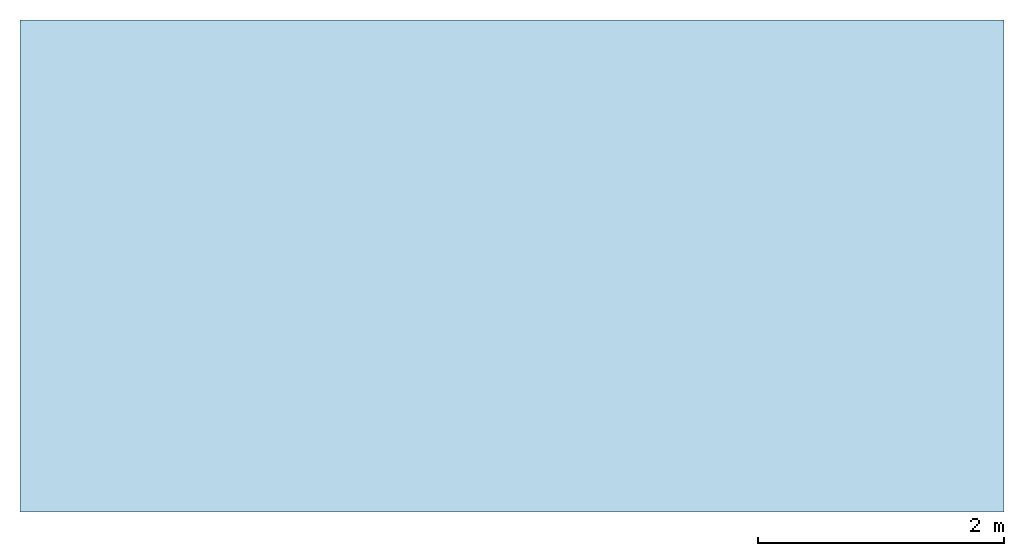
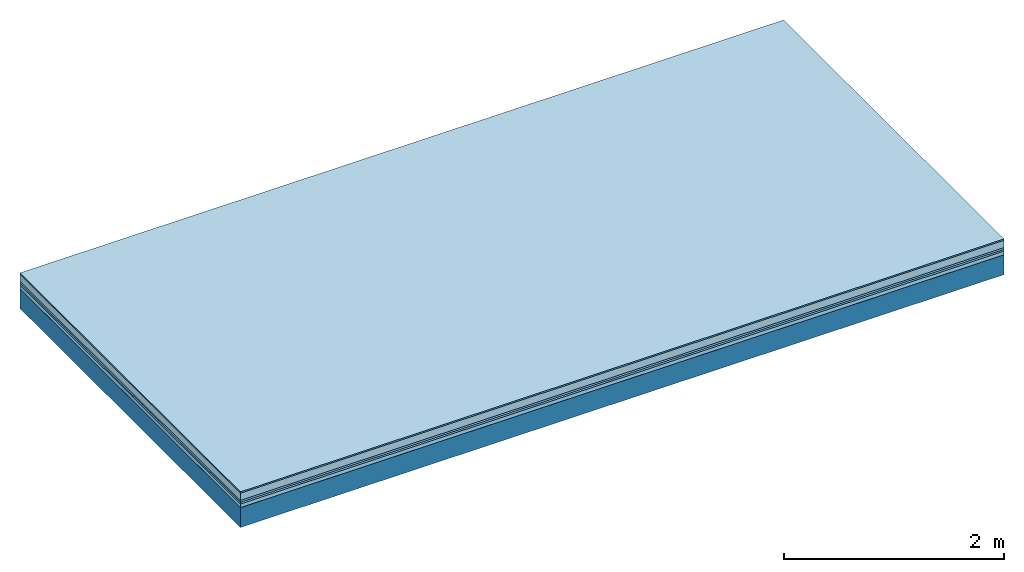
# One storey: 6 plates, 1 member, 1 element without a shape of its own.
"""IFC4 building model written with IfcOpenShell, lengths in metres."""

from ifc_helpers import new_model, si_unit, derived_unit, direction, frame, frame_2d, origin, origin_with_axes, place, context, project, spatial, rectangle, extrude, material, layer, layer_set, type_object, element, aggregate, save


model = new_model("IFC4")

# Units and contexts
plan_context = context("Plan", 3, precision=1e-05, world=origin(), true_north=direction((0.0, 1.0)))
model_context = context("Model", 3, precision=1e-05, world=origin(), true_north=direction((0.0, 1.0)))
ifc_project = project(units=[si_unit("LENGTHUNIT", "METRE"), derived_unit("SOUNDPRESSUREUNIT", [(si_unit("PRESSUREUNIT", "PASCAL", prefix="MICRO"), 0)]), si_unit("ENERGYUNIT", "JOULE", prefix="MEGA"), si_unit("MASSUNIT", "GRAM", prefix="KILO"), derived_unit("THERMALTRANSMITTANCEUNIT", [(si_unit("POWERUNIT", "WATT"), 1), (si_unit("AREAUNIT", "SQUARE_METRE"), -1), (si_unit("THERMODYNAMICTEMPERATUREUNIT", "KELVIN"), -1)]), derived_unit("AREADENSITYUNIT", [(si_unit("MASSUNIT", "GRAM", prefix="KILO"), 1), (si_unit("AREAUNIT", "SQUARE_METRE"), -1)]), derived_unit("USERDEFINED", [(si_unit("ENERGYUNIT", "JOULE", prefix="MEGA"), 1), (si_unit("AREAUNIT", "SQUARE_METRE"), -1)])], contexts=[plan_context, model_context])

# Site, building, storey
site = spatial("IfcSite", under=ifc_project)
building_placement = place(None, origin())
building = spatial("IfcBuilding", under=site, at=building_placement)
storey_placement = place(building_placement, origin())
storey = spatial("IfcBuildingStorey", under=building, at=storey_placement)

# Slab, member, plates
ifc_material_1 = material(Category="11.013")
ifc_layer_1 = layer(ifc_material_1, 0.015, Name="Flooring")
ifc_material_2 = material(Name="Cement screed", Category="04.006")
ifc_layer_2 = layer(ifc_material_2, 0.08, Name="On-material")
ifc_material_3 = material(Name="Wood fiber generic product", Category="10.009")
ifc_layer_3 = layer(ifc_material_3, 0.02, Name="Impact sound insulation")
ifc_material_4 = material()
ifc_layer_4 = layer(ifc_material_4, 0.02, Name="Additional insulation")
ifc_material_5 = material(Name="Cement panels, glued on sub-floor", Category="02.007")
ifc_layer_5 = layer(ifc_material_5, 0.04, Name="on Supporting structure")
ifc_material_6 = material(Name="protection", Category="09.007")
ifc_layer_6 = layer(ifc_material_6, 0.0005, Name="Sub-floor")
ifc_material_7 = material(Name="no composite action")
ifc_layer_7 = layer(ifc_material_7, 0.0, Name="Bond")
ifc_layer_8 = layer(None, 0.22, Name="Supporting structure")
ifc_layer_set = layer_set([ifc_layer_1, ifc_layer_2, ifc_layer_3, ifc_layer_4, ifc_layer_5, ifc_layer_6, ifc_layer_7, ifc_layer_8])
slab_type = type_object("IfcSlabType", Name="A2092", PredefinedType="NOTDEFINED", material=ifc_layer_set)
slab_placement = place(None, frame((0.0, 0.0, 0.0), z_axis=(0.0, 0.0, -1.0), x_axis=(1.0, 0.0, 0.0)))
slab = element("IfcSlab", 1, at=slab_placement, inside=storey, type_object=slab_type, material=ifc_layer_set, Name="Slab #1")
ifc_material_8 = material(Name="Solid timber panel")
member_placement = place(slab_placement, origin())
member = element("IfcMember", 2, at=member_placement, material=ifc_material_8, Name="Supporting structure", context=plan_context, shape_type="SweptSolid", body=[
    extrude(rectangle(XDim=1.0, YDim=0.22, at=frame_2d((0.5, 0.11), x_axis=(1.0, 0.0))), frame((0.0, 4.0, 0.1755), z_axis=(0.0, -1.0, 0.0), x_axis=(1.0, 0.0, 0.0)), (0.0, 0.0, 1.0), 4.0),
    extrude(rectangle(XDim=1.0, YDim=0.22, at=frame_2d((0.5, 0.11), x_axis=(1.0, 0.0))), frame((1.0, 4.0, 0.1755), z_axis=(0.0, -1.0, 0.0), x_axis=(1.0, 0.0, 0.0)), (0.0, 0.0, 1.0), 4.0),
    extrude(rectangle(XDim=1.0, YDim=0.22, at=frame_2d((0.5, 0.11), x_axis=(1.0, 0.0))), frame((2.0, 4.0, 0.1755), z_axis=(0.0, -1.0, 0.0), x_axis=(1.0, 0.0, 0.0)), (0.0, 0.0, 1.0), 4.0),
    extrude(rectangle(XDim=1.0, YDim=0.22, at=frame_2d((0.5, 0.11), x_axis=(1.0, 0.0))), frame((3.0, 4.0, 0.1755), z_axis=(0.0, -1.0, 0.0), x_axis=(1.0, 0.0, 0.0)), (0.0, 0.0, 1.0), 4.0),
    extrude(rectangle(XDim=1.0, YDim=0.22, at=frame_2d((0.5, 0.11), x_axis=(1.0, 0.0))), frame((4.0, 4.0, 0.1755), z_axis=(0.0, -1.0, 0.0), x_axis=(1.0, 0.0, 0.0)), (0.0, 0.0, 1.0), 4.0),
    extrude(rectangle(XDim=1.0, YDim=0.22, at=frame_2d((0.5, 0.11), x_axis=(1.0, 0.0))), frame((5.0, 4.0, 0.1755), z_axis=(0.0, -1.0, 0.0), x_axis=(1.0, 0.0, 0.0)), (0.0, 0.0, 1.0), 4.0),
    extrude(rectangle(XDim=1.0, YDim=0.22, at=frame_2d((0.5, 0.11), x_axis=(1.0, 0.0))), frame((6.0, 4.0, 0.1755), z_axis=(0.0, -1.0, 0.0), x_axis=(1.0, 0.0, 0.0)), (0.0, 0.0, 1.0), 4.0),
    extrude(rectangle(XDim=1.0, YDim=0.22, at=frame_2d((0.5, 0.11), x_axis=(1.0, 0.0))), frame((7.0, 4.0, 0.1755), z_axis=(0.0, -1.0, 0.0), x_axis=(1.0, 0.0, 0.0)), (0.0, 0.0, 1.0), 4.0),
])
plate_1_placement = place(slab_placement, origin())
plate_1 = element("IfcPlate", 3, at=plate_1_placement, material=ifc_material_1, Name="Flooring", context=plan_context, shape_type="SweptSolid", body=[
    extrude(rectangle(XDim=8.0, YDim=4.0, at=frame_2d((4.0, 2.0), x_axis=(1.0, 0.0))), origin_with_axes(), (0.0, 0.0, 1.0), 0.015),
])
plate_2_placement = place(slab_placement, origin())
plate_2 = element("IfcPlate", 4, at=plate_2_placement, material=ifc_material_2, Name="On-material", context=plan_context, shape_type="SweptSolid", body=[
    extrude(rectangle(XDim=8.0, YDim=4.0, at=frame_2d((4.0, 2.0), x_axis=(1.0, 0.0))), frame((0.0, 0.0, 0.015), z_axis=(0.0, 0.0, 1.0), x_axis=(1.0, 0.0, 0.0)), (0.0, 0.0, 1.0), 0.08),
])
plate_3_placement = place(slab_placement, origin())
plate_3 = element("IfcPlate", 5, at=plate_3_placement, material=ifc_material_3, Name="Impact sound insulation", context=plan_context, shape_type="SweptSolid", body=[
    extrude(rectangle(XDim=8.0, YDim=4.0, at=frame_2d((4.0, 2.0), x_axis=(1.0, 0.0))), frame((0.0, 0.0, 0.095), z_axis=(0.0, 0.0, 1.0), x_axis=(1.0, 0.0, 0.0)), (0.0, 0.0, 1.0), 0.02),
])
plate_4_placement = place(slab_placement, origin())
plate_4 = element("IfcPlate", 6, at=plate_4_placement, material=ifc_material_4, Name="Additional insulation", context=plan_context, shape_type="SweptSolid", body=[
    extrude(rectangle(XDim=8.0, YDim=4.0, at=frame_2d((4.0, 2.0), x_axis=(1.0, 0.0))), frame((0.0, 0.0, 0.115), z_axis=(0.0, 0.0, 1.0), x_axis=(1.0, 0.0, 0.0)), (0.0, 0.0, 1.0), 0.02),
])
plate_5_placement = place(slab_placement, origin())
plate_5 = element("IfcPlate", 7, at=plate_5_placement, material=ifc_material_5, Name="on Supporting structure", context=plan_context, shape_type="SweptSolid", body=[
    extrude(rectangle(XDim=8.0, YDim=4.0, at=frame_2d((4.0, 2.0), x_axis=(1.0, 0.0))), frame((0.0, 0.0, 0.135), z_axis=(0.0, 0.0, 1.0), x_axis=(1.0, 0.0, 0.0)), (0.0, 0.0, 1.0), 0.04),
])
plate_6_placement = place(slab_placement, origin())
plate_6 = element("IfcPlate", 8, at=plate_6_placement, material=ifc_material_6, Name="Sub-floor", context=plan_context, shape_type="SweptSolid", body=[
    extrude(rectangle(XDim=8.0, YDim=4.0, at=frame_2d((4.0, 2.0), x_axis=(1.0, 0.0))), frame((0.0, 0.0, 0.175), z_axis=(0.0, 0.0, 1.0), x_axis=(1.0, 0.0, 0.0)), (0.0, 0.0, 1.0), 0.0005),
])
aggregate(slab, [plate_1, plate_2, plate_3, plate_4, plate_5, plate_6, member])

save(model, "model.ifc")
